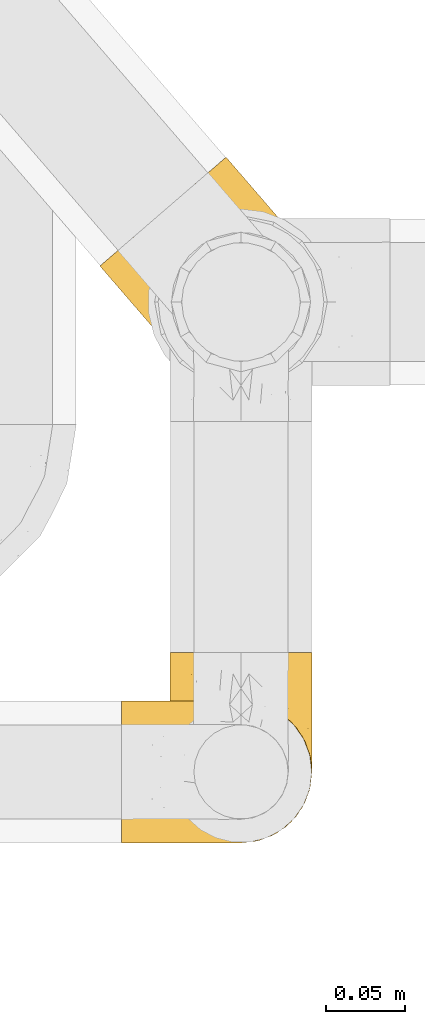
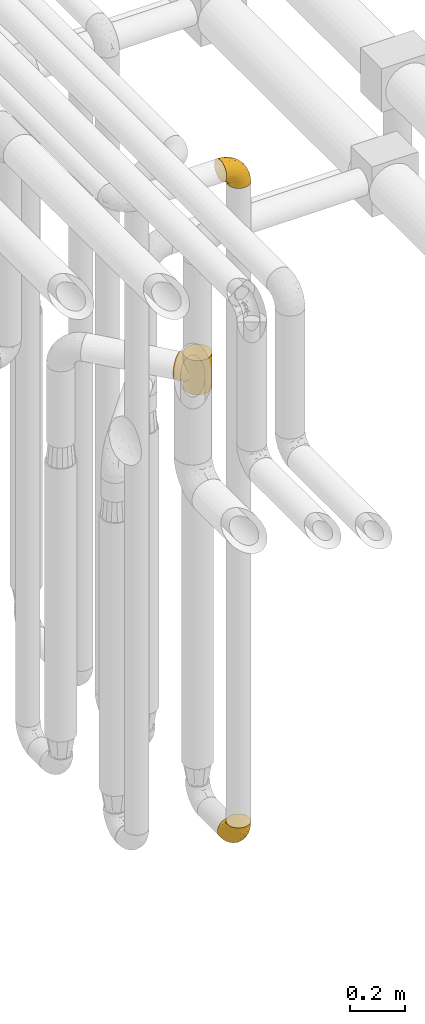
# One storey, part 195 of 827: 3 coverings.
"""IFC2X3 building model written with IfcOpenShell, lengths in millimetres."""

from ifc_helpers import new_model, entity, si_unit, converted_unit, derived_unit, direction, frame, origin, place, context, subcontext, project, spatial, faceted_brep, element, save


model = new_model("IFC2X3")

# Units and contexts
model_context = context("Model", 3, precision=0.01, world=origin(), true_north=direction((6.12303176911189e-17, 1.0)))
body_context = subcontext(model_context, "Body", "Model", "MODEL_VIEW")
ifc_project = project(units=[si_unit("LENGTHUNIT", "METRE", prefix="MILLI"), si_unit("AREAUNIT", "SQUARE_METRE"), si_unit("VOLUMEUNIT", "CUBIC_METRE"), converted_unit("PLANEANGLEUNIT", "DEGREE", entity("IfcRatioMeasure", 0.0174532925199433), si_unit("PLANEANGLEUNIT", "RADIAN"), dimensions=[0, 0, 0, 0, 0, 0, 0]), si_unit("MASSUNIT", "GRAM", prefix="KILO"), derived_unit("MASSDENSITYUNIT", [(si_unit("MASSUNIT", "GRAM", prefix="KILO"), 1), (si_unit("LENGTHUNIT", "METRE"), -3)]), derived_unit("MOMENTOFINERTIAUNIT", [(si_unit("LENGTHUNIT", "METRE"), 4)]), si_unit("TIMEUNIT", "SECOND"), si_unit("FREQUENCYUNIT", "HERTZ"), si_unit("THERMODYNAMICTEMPERATUREUNIT", "DEGREE_CELSIUS"), derived_unit("THERMALTRANSMITTANCEUNIT", [(si_unit("MASSUNIT", "GRAM", prefix="KILO"), 1), (si_unit("THERMODYNAMICTEMPERATUREUNIT", "KELVIN"), -1), (si_unit("TIMEUNIT", "SECOND"), -3)]), derived_unit("VOLUMETRICFLOWRATEUNIT", [(si_unit("LENGTHUNIT", "METRE"), 3), (si_unit("TIMEUNIT", "SECOND"), -1)]), derived_unit("MASSFLOWRATEUNIT", [(si_unit("MASSUNIT", "GRAM", prefix="KILO"), 1), (si_unit("TIMEUNIT", "SECOND"), -1)]), derived_unit("ROTATIONALFREQUENCYUNIT", [(si_unit("TIMEUNIT", "SECOND"), -1)]), si_unit("ELECTRICCURRENTUNIT", "AMPERE"), si_unit("ELECTRICVOLTAGEUNIT", "VOLT"), si_unit("POWERUNIT", "WATT"), si_unit("FORCEUNIT", "NEWTON", prefix="KILO"), si_unit("ILLUMINANCEUNIT", "LUX"), si_unit("LUMINOUSFLUXUNIT", "LUMEN"), si_unit("LUMINOUSINTENSITYUNIT", "CANDELA"), derived_unit("USERDEFINED", [(si_unit("MASSUNIT", "GRAM", prefix="KILO"), -1), (si_unit("LENGTHUNIT", "METRE"), -2), (si_unit("TIMEUNIT", "SECOND"), 3), (si_unit("LUMINOUSFLUXUNIT", "LUMEN"), 1)]), derived_unit("LINEARVELOCITYUNIT", [(si_unit("LENGTHUNIT", "METRE"), 1), (si_unit("TIMEUNIT", "SECOND"), -1)]), si_unit("PRESSUREUNIT", "PASCAL"), derived_unit("USERDEFINED", [(si_unit("LENGTHUNIT", "METRE"), -2), (si_unit("MASSUNIT", "GRAM", prefix="KILO"), 1), (si_unit("TIMEUNIT", "SECOND"), -2)]), derived_unit("LINEARFORCEUNIT", [(si_unit("MASSUNIT", "GRAM", prefix="KILO"), 1), (si_unit("LENGTHUNIT", "METRE"), 1), (si_unit("TIMEUNIT", "SECOND"), -2), (si_unit("LENGTHUNIT", "METRE"), -1)]), derived_unit("PLANARFORCEUNIT", [(si_unit("MASSUNIT", "GRAM", prefix="KILO"), 1), (si_unit("LENGTHUNIT", "METRE"), 1), (si_unit("TIMEUNIT", "SECOND"), -2), (si_unit("LENGTHUNIT", "METRE"), -2)])], contexts=[model_context])

# Site, building, storey
site_placement = place(None, origin())
site = spatial("IfcSite", under=ifc_project, at=site_placement, CompositionType="ELEMENT")
building_placement = place(site_placement, origin())
building = spatial("IfcBuilding", under=site, at=building_placement, CompositionType="ELEMENT")
storey_placement = place(building_placement, frame((0.0, 0.0, 28200.0)))
storey = spatial("IfcBuildingStorey", under=building, at=storey_placement, Name="08", CompositionType="ELEMENT", Elevation=28200.0)

# Coverings
covering_1_placement = place(storey_placement, frame((36928.29, 9734.28, 353.25)))
element("IfcCovering", 1, at=covering_1_placement, inside=storey, Name=":ADSK_", ObjectType=":ADSK_", PredefinedType="INSULATION", context=body_context, shape_type="Brep", body=[
    faceted_brep([(2.73, 36.69, 122.75), (6.07, 27.15, 122.75), (11.45, 18.59, 122.75), (18.6, 11.44, 122.75), (27.16, 6.06, 122.75), (36.7, 2.73, 122.75), (46.75, 1.6, 122.75), (56.8, 2.73, 122.75), (66.34, 6.07, 122.75), (74.9, 11.45, 122.75), (82.05, 18.6, 122.75), (87.43, 27.16, 122.75), (90.76, 36.7, 122.75), (91.9, 46.75, 122.75), (90.76, 56.8, 122.75), (87.42, 66.34, 122.75), (82.04, 74.9, 122.75), (74.89, 82.05, 122.75), (66.33, 87.43, 122.75), (56.79, 90.76, 122.75), (46.75, 91.9, 122.75), (36.69, 90.76, 122.75), (27.15, 87.42, 122.75), (18.59, 82.04, 122.75), (11.44, 74.89, 122.75), (6.06, 66.33, 122.75), (2.73, 56.79, 122.75), (1.6, 46.75, 122.75), (58.43, 122.75, 90.36), (69.32, 122.75, 85.85), (78.67, 122.75, 78.67), (85.85, 122.75, 69.32), (90.36, 122.75, 58.43), (91.9, 122.75, 46.75), (90.36, 122.75, 35.06), (85.85, 122.75, 24.17), (78.67, 122.75, 14.82), (69.32, 122.75, 7.64), (58.43, 122.75, 3.13), (46.75, 122.75, 1.6), (35.06, 122.75, 3.13), (24.17, 122.75, 7.64), (14.82, 122.75, 14.82), (7.64, 122.75, 24.17), (3.13, 122.75, 35.06), (1.6, 122.75, 46.75), (3.13, 122.75, 58.43), (7.64, 122.75, 69.32), (14.82, 122.75, 78.67), (24.17, 122.75, 85.85), (35.06, 122.75, 90.36), (46.75, 122.75, 91.9), (46.75, 24.73, 51.54), (38.29, 29.08, 47.17), (46.75, 38.13, 38.13), (46.75, 85.31, 7.52), (38.96, 93.59, 5.85), (46.75, 100.54, 5.11), (33.86, 63.54, 19.2), (31.42, 38.98, 38.98), (21.63, 50.71, 35.02), (30.84, 93.33, 8.21), (22.16, 75.2, 19.28), (20.56, 100.46, 12.19), (2.29, 41.6, 101.39), (7.18, 80.86, 34.43), (12.6, 94.87, 20.95), (14.0, 67.96, 30.74), (2.81, 52.16, 72.93), (6.65, 52.1, 56.64), (6.11, 36.74, 80.81), (16.62, 17.11, 93.43), (9.76, 23.24, 100.76), (12.46, 29.18, 74.27), (1.6, 52.53, 93.66), (1.6, 60.77, 81.33), (1.6, 69.01, 69.01), (2.46, 100.68, 40.87), (5.91, 103.79, 29.38), (36.97, 16.37, 67.05), (46.75, 7.52, 85.31), (33.09, 7.31, 93.68), (1.6, 93.66, 52.53), (1.6, 102.83, 50.71), (1.6, 112.01, 48.88), (25.62, 18.17, 72.77), (3.14, 71.97, 51.21), (23.92, 9.83, 101.18), (46.75, 5.11, 100.54), (13.58, 45.97, 48.74), (1.6, 48.88, 112.01), (1.6, 50.71, 102.83), (18.5, 22.83, 73.88), (46.75, 51.54, 24.73), (1.6, 81.33, 60.77), (4.96, 31.74, 103.08), (20.84, 32.48, 54.8), (46.75, 68.42, 16.13), (30.52, 25.33, 55.92), (46.75, 16.13, 68.42), (27.29, 92.29, 104.98), (36.89, 94.12, 108.58), (33.6, 100.97, 98.21), (2.54, 95.91, 61.56), (3.27, 107.9, 60.69), (16.85, 87.24, 100.0), (21.91, 95.46, 95.88), (13.5, 90.41, 90.81), (3.96, 74.17, 84.88), (3.52, 83.77, 73.29), (12.17, 76.72, 113.4), (18.93, 84.44, 109.8), (9.34, 76.42, 102.13), (3.12, 90.07, 67.29), (5.67, 99.69, 70.34), (2.51, 61.74, 95.15), (2.53, 58.16, 105.49), (8.35, 112.6, 71.5), (35.39, 110.45, 92.87), (46.75, 107.32, 96.03), (15.1, 108.48, 81.34), (5.27, 66.63, 107.44), (27.43, 115.23, 88.36), (24.89, 105.79, 90.43), (29.71, 89.6, 114.37), (5.07, 69.39, 98.41), (2.88, 66.99, 88.73), (9.69, 102.31, 76.89), (15.51, 99.54, 86.08), (2.27, 55.27, 112.64), (10.03, 82.03, 94.21), (46.75, 94.71, 112.22), (46.75, 96.03, 107.32), (8.83, 94.11, 79.95), (7.16, 84.21, 84.51), (46.75, 101.67, 101.67), (46.75, 112.22, 94.71), (78.39, 108.48, 81.34), (83.8, 102.31, 76.89), (77.97, 99.54, 86.08), (84.66, 94.11, 79.96), (58.1, 110.46, 92.87), (81.31, 76.74, 113.41), (91.9, 50.71, 102.83), (90.96, 58.17, 105.5), (91.22, 55.27, 112.64), (56.59, 94.12, 108.58), (66.18, 92.3, 104.98), (59.87, 100.98, 98.2), (88.42, 69.41, 98.4), (84.13, 76.44, 102.13), (88.22, 66.65, 107.44), (66.06, 115.24, 88.36), (91.9, 102.83, 50.71), (91.9, 112.01, 48.88), (83.44, 82.05, 94.22), (76.62, 87.25, 100.01), (85.14, 112.6, 71.5), (90.22, 107.9, 60.69), (91.9, 93.66, 52.53), (71.55, 95.48, 95.89), (63.77, 89.6, 114.37), (91.9, 60.77, 81.33), (91.9, 69.01, 69.01), (89.53, 74.17, 84.88), (91.9, 48.88, 112.01), (74.55, 84.45, 109.8), (90.95, 95.91, 61.56), (90.37, 90.07, 67.29), (91.9, 81.33, 60.77), (90.98, 61.75, 95.14), (89.97, 83.77, 73.29), (86.32, 84.21, 84.53), (91.9, 52.53, 93.66), (79.97, 90.42, 90.82), (90.61, 67.0, 88.73), (87.82, 99.69, 70.34), (68.6, 105.8, 90.43), (80.89, 94.87, 20.95), (86.31, 80.86, 34.43), (79.49, 67.95, 30.74), (71.33, 75.17, 19.29), (71.88, 50.65, 35.07), (90.35, 71.97, 51.21), (86.85, 52.08, 56.67), (72.67, 32.46, 54.85), (62.08, 38.98, 38.98), (87.58, 103.79, 29.38), (91.03, 100.68, 40.87), (59.62, 63.54, 19.2), (62.65, 93.32, 8.21), (54.53, 93.59, 5.85), (72.93, 100.44, 12.19), (90.68, 52.17, 72.93), (87.39, 36.75, 80.83), (91.2, 41.61, 101.39), (60.41, 7.31, 93.69), (76.88, 17.12, 93.43), (56.53, 16.37, 67.04), (83.74, 23.26, 100.76), (67.88, 18.17, 72.78), (62.99, 25.33, 55.93), (69.58, 9.84, 101.18), (81.04, 29.19, 74.27), (75.0, 22.84, 73.89), (88.53, 31.75, 103.09), (79.93, 45.96, 48.78), (55.21, 29.07, 47.19)], [[[0, 1, 2, 3, 4, 5, 6, 7, 8, 9, 10, 11, 12, 13, 14, 15, 16, 17, 18, 19, 20, 21, 22, 23, 24, 25, 26, 27]], [[28, 29, 30, 31, 32, 33, 34, 35, 36, 37, 38, 39, 40, 41, 42, 43, 44, 45, 46, 47, 48, 49, 50, 51]], [[52, 53, 54]], [[55, 56, 57]], [[58, 59, 60]], [[61, 62, 63]], [[27, 64, 0]], [[65, 66, 67]], [[41, 40, 61]], [[68, 69, 70]], [[66, 43, 42]], [[63, 42, 41]], [[71, 72, 73]], [[72, 2, 1]], [[68, 74, 75, 76]], [[45, 44, 77]], [[43, 78, 44]], [[79, 80, 81]], [[77, 82, 83, 84, 45]], [[79, 81, 85]], [[71, 2, 72]], [[65, 86, 77]], [[4, 81, 5]], [[66, 65, 78]], [[4, 3, 87]], [[81, 88, 5]], [[63, 66, 42]], [[68, 70, 64]], [[67, 60, 89]], [[71, 3, 2]], [[64, 27, 90, 91, 74]], [[92, 71, 73]], [[40, 57, 56]], [[59, 93, 54]], [[86, 76, 94, 82]], [[1, 0, 95]], [[58, 62, 61]], [[60, 96, 89]], [[85, 81, 87]], [[56, 97, 58]], [[65, 67, 69]], [[87, 81, 4]], [[67, 89, 69]], [[61, 63, 41]], [[95, 72, 1]], [[73, 72, 70]], [[69, 73, 70]], [[73, 89, 96]], [[3, 71, 87]], [[85, 87, 71]], [[58, 61, 56]], [[59, 58, 93]], [[76, 86, 68]], [[69, 89, 73]], [[68, 86, 69]], [[65, 69, 86]], [[68, 64, 74]], [[95, 64, 70]], [[98, 79, 85]], [[79, 52, 99, 80]], [[66, 62, 67]], [[62, 58, 60]], [[62, 60, 67]], [[59, 98, 96]], [[59, 96, 60]], [[96, 85, 92]], [[88, 81, 80]], [[88, 6, 5]], [[66, 63, 62]], [[64, 95, 0]], [[72, 95, 70]], [[77, 44, 78]], [[86, 82, 77]], [[40, 39, 57]], [[96, 98, 85]], [[40, 56, 61]], [[66, 78, 43]], [[77, 78, 65]], [[79, 98, 53]], [[96, 92, 73]], [[85, 71, 92]], [[97, 56, 55]], [[97, 93, 58]], [[53, 98, 59]], [[54, 53, 59]], [[79, 53, 52]], [[100, 101, 102]], [[46, 45, 84, 83]], [[103, 104, 82]], [[82, 104, 83]], [[105, 106, 107]], [[108, 109, 76]], [[110, 111, 112]], [[103, 113, 114]], [[115, 74, 116]], [[48, 47, 117]], [[118, 102, 119]], [[49, 48, 120]], [[74, 91, 116]], [[116, 121, 115]], [[49, 122, 50]], [[123, 106, 102]], [[124, 111, 22]], [[125, 126, 115]], [[23, 22, 111]], [[24, 110, 121]], [[120, 127, 128]], [[90, 26, 129]], [[27, 26, 90]], [[121, 125, 115]], [[24, 121, 25]], [[130, 105, 107]], [[129, 25, 116]], [[21, 20, 131]], [[120, 123, 122]], [[112, 105, 130]], [[50, 118, 51]], [[21, 124, 22]], [[101, 131, 132]], [[117, 120, 48]], [[24, 23, 110]], [[127, 114, 133]], [[75, 108, 76]], [[107, 134, 130]], [[133, 114, 113]], [[129, 116, 91]], [[25, 121, 116]], [[121, 112, 125]], [[75, 74, 115]], [[101, 135, 102]], [[131, 101, 21]], [[101, 100, 124]], [[128, 127, 133]], [[119, 136, 51, 118]], [[104, 47, 46]], [[83, 104, 46]], [[117, 104, 114]], [[101, 124, 21]], [[111, 124, 100]], [[102, 118, 123]], [[133, 134, 107]], [[111, 110, 23]], [[114, 104, 103]], [[94, 76, 109]], [[121, 110, 112]], [[122, 118, 50]], [[134, 109, 108]], [[133, 107, 128]], [[112, 108, 125]], [[126, 125, 108]], [[108, 75, 126]], [[75, 115, 126]], [[109, 134, 133]], [[130, 108, 112]], [[108, 130, 134]], [[105, 112, 111]], [[111, 100, 105]], [[106, 105, 100]], [[102, 106, 100]], [[128, 106, 123]], [[90, 129, 91]], [[25, 129, 26]], [[104, 117, 47]], [[117, 114, 127]], [[82, 94, 103]], [[113, 94, 109]], [[94, 113, 103]], [[133, 113, 109]], [[106, 128, 107]], [[123, 120, 128]], [[120, 122, 49]], [[118, 122, 123]], [[135, 101, 132]], [[135, 119, 102]], [[117, 127, 120]], [[30, 29, 137]], [[138, 139, 140]], [[51, 136, 119, 141]], [[142, 17, 16]], [[143, 144, 145]], [[146, 147, 148]], [[149, 150, 151]], [[152, 29, 28]], [[33, 32, 153, 154]], [[150, 155, 156]], [[157, 31, 30]], [[153, 158, 159]], [[29, 152, 137]], [[148, 141, 119]], [[156, 160, 147]], [[148, 135, 146]], [[137, 138, 157]], [[19, 161, 146]], [[162, 163, 164]], [[14, 13, 165]], [[153, 32, 158]], [[147, 161, 166]], [[18, 17, 166]], [[167, 168, 169]], [[166, 150, 156]], [[151, 150, 142]], [[151, 170, 149]], [[151, 16, 15]], [[171, 140, 172]], [[165, 143, 145]], [[173, 170, 144]], [[142, 166, 17]], [[19, 131, 20]], [[144, 170, 151]], [[18, 161, 19]], [[173, 144, 143]], [[140, 139, 174]], [[171, 164, 163]], [[164, 172, 155]], [[151, 15, 144]], [[145, 15, 14]], [[173, 162, 170]], [[149, 175, 164]], [[19, 146, 131]], [[132, 131, 146]], [[160, 148, 147]], [[159, 158, 167]], [[135, 132, 146]], [[158, 32, 31]], [[157, 158, 31]], [[167, 158, 176]], [[166, 161, 18]], [[146, 161, 147]], [[148, 177, 141]], [[171, 168, 140]], [[171, 163, 169]], [[151, 142, 16]], [[166, 142, 150]], [[152, 141, 177]], [[51, 141, 28]], [[138, 140, 176]], [[172, 140, 174]], [[175, 149, 170]], [[164, 150, 149]], [[170, 162, 175]], [[162, 164, 175]], [[155, 172, 174]], [[171, 172, 164]], [[155, 174, 156]], [[164, 155, 150]], [[160, 156, 174]], [[147, 166, 156]], [[139, 160, 174]], [[148, 160, 177]], [[15, 145, 144]], [[165, 145, 14]], [[137, 157, 30]], [[158, 157, 176]], [[168, 167, 176]], [[169, 159, 167]], [[140, 168, 176]], [[169, 168, 171]], [[137, 177, 139]], [[160, 139, 177]], [[141, 152, 28]], [[137, 152, 177]], [[148, 119, 135]], [[157, 138, 176]], [[139, 138, 137]], [[178, 179, 180]], [[181, 180, 182]], [[179, 183, 184]], [[185, 186, 182]], [[187, 188, 179]], [[188, 33, 154, 153, 159]], [[181, 189, 190]], [[35, 34, 187]], [[191, 38, 190]], [[192, 178, 181]], [[179, 184, 180]], [[192, 190, 37]], [[37, 190, 38]], [[36, 35, 178]], [[54, 93, 186]], [[35, 187, 178]], [[193, 194, 184]], [[195, 173, 143, 165, 13]], [[195, 193, 173]], [[193, 163, 162, 173]], [[13, 12, 195]], [[8, 7, 196]], [[9, 197, 10]], [[198, 80, 99, 52]], [[196, 7, 88]], [[197, 199, 10]], [[182, 189, 181]], [[200, 198, 201]], [[200, 196, 198]], [[9, 8, 202]], [[194, 199, 203]], [[192, 37, 36]], [[80, 196, 88]], [[183, 159, 169, 163]], [[188, 34, 33]], [[202, 200, 197]], [[185, 203, 204]], [[202, 8, 196]], [[10, 199, 11]], [[12, 11, 205]], [[38, 191, 57]], [[189, 97, 191]], [[203, 199, 197]], [[205, 199, 194]], [[204, 203, 197]], [[184, 203, 206]], [[200, 202, 196]], [[197, 9, 202]], [[207, 54, 186]], [[97, 55, 191]], [[194, 203, 184]], [[183, 163, 193]], [[184, 206, 180]], [[183, 193, 184]], [[205, 195, 12]], [[193, 195, 194]], [[80, 198, 196]], [[207, 186, 201]], [[182, 180, 206]], [[181, 178, 180]], [[185, 182, 206]], [[182, 186, 189]], [[203, 185, 206]], [[185, 200, 201]], [[7, 6, 88]], [[178, 192, 36]], [[190, 192, 181]], [[199, 205, 11]], [[195, 205, 194]], [[159, 183, 188]], [[179, 188, 183]], [[57, 191, 55]], [[57, 39, 38]], [[189, 191, 190]], [[188, 187, 34]], [[178, 187, 179]], [[186, 93, 189]], [[197, 200, 204]], [[185, 204, 200]], [[189, 93, 97]], [[207, 198, 52]], [[185, 201, 186]], [[198, 207, 201]], [[54, 207, 52]]]),
])
covering_2_placement = place(storey_placement, frame((36897.44, 9734.28, 3322.4)))
element("IfcCovering", 2, at=covering_2_placement, inside=storey, Name=":ADSK_", ObjectType=":ADSK_", PredefinedType="INSULATION", context=body_context, shape_type="Brep", body=[
    faceted_brep([(1.6, 2.73, 87.65), (1.6, 6.07, 97.19), (1.6, 11.45, 105.75), (1.6, 18.6, 112.9), (1.6, 27.16, 118.28), (1.6, 36.7, 121.61), (1.6, 46.75, 122.75), (1.6, 56.8, 121.61), (1.6, 66.34, 118.27), (1.6, 74.9, 112.89), (1.6, 82.05, 105.74), (1.6, 87.43, 97.18), (1.6, 90.76, 87.64), (1.6, 91.9, 77.6), (1.6, 90.76, 67.54), (1.6, 87.42, 58.0), (1.6, 82.04, 49.44), (1.6, 74.89, 42.29), (1.6, 66.33, 36.91), (1.6, 56.79, 33.58), (1.6, 46.75, 32.45), (1.6, 36.69, 33.58), (1.6, 27.15, 36.92), (1.6, 18.59, 42.3), (1.6, 11.44, 49.45), (1.6, 6.06, 58.01), (1.6, 2.73, 67.55), (1.6, 1.6, 77.6), (33.98, 58.43, 1.6), (38.49, 69.32, 1.6), (45.67, 78.67, 1.6), (55.02, 85.85, 1.6), (65.91, 90.36, 1.6), (77.6, 91.9, 1.6), (89.28, 90.36, 1.6), (100.17, 85.85, 1.6), (109.52, 78.67, 1.6), (116.7, 69.32, 1.6), (121.21, 58.43, 1.6), (122.75, 46.75, 1.6), (121.21, 35.06, 1.6), (116.7, 24.17, 1.6), (109.52, 14.82, 1.6), (100.17, 7.64, 1.6), (89.28, 3.13, 1.6), (77.6, 1.6, 1.6), (65.91, 3.13, 1.6), (55.02, 7.64, 1.6), (45.67, 14.82, 1.6), (38.49, 24.17, 1.6), (33.98, 35.06, 1.6), (32.45, 46.75, 1.6), (72.81, 46.75, 99.61), (77.17, 38.29, 95.26), (86.21, 46.75, 86.21), (116.82, 46.75, 39.03), (118.49, 38.96, 30.75), (119.23, 46.75, 23.8), (105.14, 33.86, 60.8), (85.37, 31.42, 85.37), (89.33, 21.63, 73.64), (116.14, 30.84, 31.01), (105.06, 22.16, 49.14), (112.15, 20.56, 23.88), (22.95, 2.29, 82.74), (89.91, 7.18, 43.48), (103.39, 12.6, 29.47), (93.6, 14.0, 56.38), (51.41, 2.81, 72.18), (67.71, 6.65, 72.24), (43.53, 6.11, 87.6), (30.91, 16.62, 107.24), (23.58, 9.76, 101.1), (50.07, 12.46, 95.16), (30.68, 1.6, 71.81), (43.01, 1.6, 63.57), (55.34, 1.6, 55.34), (83.48, 2.46, 23.66), (94.96, 5.91, 20.55), (57.29, 36.97, 107.97), (39.03, 46.75, 116.82), (30.66, 33.09, 117.03), (71.81, 1.6, 30.68), (73.63, 1.6, 21.51), (75.46, 1.6, 12.33), (51.57, 25.62, 106.17), (73.13, 3.14, 52.37), (23.16, 23.92, 114.51), (23.8, 46.75, 119.23), (75.6, 13.58, 78.37), (12.33, 1.6, 75.46), (21.51, 1.6, 73.63), (50.46, 18.5, 101.51), (99.61, 46.75, 72.81), (63.57, 1.6, 43.01), (21.26, 4.96, 92.6), (69.54, 20.84, 91.86), (108.21, 46.75, 55.92), (68.42, 30.52, 99.01), (55.92, 46.75, 108.21), (19.36, 27.29, 32.05), (15.76, 36.89, 30.22), (26.13, 33.6, 23.37), (62.78, 2.54, 28.43), (63.65, 3.27, 16.44), (24.34, 16.85, 37.1), (28.46, 21.91, 28.88), (33.53, 13.5, 33.93), (39.46, 3.96, 50.17), (51.05, 3.52, 40.57), (10.94, 12.17, 47.62), (14.55, 18.93, 39.9), (22.21, 9.34, 47.92), (57.05, 3.12, 34.27), (54.0, 5.67, 24.65), (29.19, 2.51, 62.6), (18.85, 2.53, 66.18), (52.84, 8.35, 11.74), (31.47, 35.39, 13.89), (28.31, 46.75, 17.02), (43.0, 15.1, 15.86), (16.9, 5.27, 57.71), (35.98, 27.43, 9.11), (33.91, 24.89, 18.55), (9.97, 29.71, 34.74), (25.93, 5.07, 54.95), (35.61, 2.88, 57.35), (47.45, 9.69, 22.03), (38.26, 15.51, 24.8), (11.7, 2.27, 69.07), (30.13, 10.03, 42.31), (12.12, 46.75, 29.63), (17.02, 46.75, 28.31), (44.39, 8.83, 30.23), (39.83, 7.16, 40.13), (22.67, 46.75, 22.67), (29.63, 46.75, 12.12), (43.0, 78.39, 15.86), (47.45, 83.8, 22.03), (38.26, 77.97, 24.8), (44.38, 84.66, 30.23), (31.47, 58.1, 13.88), (10.93, 81.31, 47.61), (21.51, 91.9, 73.63), (18.84, 90.96, 66.17), (11.7, 91.22, 69.07), (15.76, 56.59, 30.22), (19.36, 66.18, 32.04), (26.14, 59.87, 23.36), (25.94, 88.42, 54.93), (22.21, 84.13, 47.91), (16.9, 88.22, 57.69), (35.98, 66.06, 9.1), (73.63, 91.9, 21.51), (75.46, 91.9, 12.33), (30.12, 83.44, 42.29), (24.33, 76.62, 37.09), (52.84, 85.14, 11.74), (63.65, 90.22, 16.44), (71.81, 91.9, 30.68), (28.45, 71.55, 28.86), (9.97, 63.77, 34.74), (43.01, 91.9, 63.57), (55.34, 91.9, 55.34), (39.46, 89.53, 50.17), (12.33, 91.9, 75.46), (14.54, 74.55, 39.89), (62.78, 90.95, 28.43), (57.05, 90.37, 34.27), (63.57, 91.9, 43.01), (29.2, 90.98, 62.59), (51.05, 89.97, 40.57), (39.81, 86.32, 40.13), (30.68, 91.9, 71.81), (33.52, 79.97, 33.92), (35.61, 90.61, 57.34), (54.0, 87.82, 24.65), (33.91, 68.6, 18.54), (103.39, 80.89, 29.47), (89.91, 86.31, 43.48), (93.6, 79.49, 56.4), (105.05, 71.33, 49.17), (89.27, 71.88, 73.69), (73.13, 90.35, 52.37), (67.67, 86.85, 72.26), (69.49, 72.67, 91.88), (85.36, 62.08, 85.36), (94.96, 87.58, 20.55), (83.48, 91.03, 23.66), (105.14, 59.62, 60.8), (116.13, 62.65, 31.02), (118.49, 54.53, 30.75), (112.15, 72.93, 23.9), (51.41, 90.68, 72.17), (43.51, 87.39, 87.59), (22.95, 91.2, 82.74), (30.66, 60.41, 117.03), (30.91, 76.88, 107.23), (57.3, 56.53, 107.97), (23.58, 83.74, 101.08), (51.56, 67.88, 106.17), (68.41, 62.99, 99.01), (23.16, 69.58, 114.5), (50.07, 81.04, 95.15), (50.45, 75.0, 101.5), (21.25, 88.53, 92.59), (75.56, 79.93, 78.38), (77.16, 55.21, 95.27)], [[[0, 1, 2, 3, 4, 5, 6, 7, 8, 9, 10, 11, 12, 13, 14, 15, 16, 17, 18, 19, 20, 21, 22, 23, 24, 25, 26, 27]], [[28, 29, 30, 31, 32, 33, 34, 35, 36, 37, 38, 39, 40, 41, 42, 43, 44, 45, 46, 47, 48, 49, 50, 51]], [[52, 53, 54]], [[55, 56, 57]], [[58, 59, 60]], [[61, 62, 63]], [[27, 64, 0]], [[65, 66, 67]], [[41, 40, 61]], [[68, 69, 70]], [[66, 43, 42]], [[63, 42, 41]], [[71, 72, 73]], [[72, 2, 1]], [[68, 74, 75, 76]], [[45, 44, 77]], [[43, 78, 44]], [[79, 80, 81]], [[77, 82, 83, 84, 45]], [[79, 81, 85]], [[71, 2, 72]], [[65, 86, 77]], [[4, 81, 5]], [[66, 65, 78]], [[4, 3, 87]], [[81, 88, 5]], [[63, 66, 42]], [[68, 70, 64]], [[67, 60, 89]], [[71, 3, 2]], [[64, 27, 90, 91, 74]], [[92, 71, 73]], [[40, 57, 56]], [[59, 93, 54]], [[86, 76, 94, 82]], [[1, 0, 95]], [[58, 62, 61]], [[60, 96, 89]], [[85, 81, 87]], [[56, 97, 58]], [[65, 67, 69]], [[87, 81, 4]], [[67, 89, 69]], [[61, 63, 41]], [[95, 72, 1]], [[73, 72, 70]], [[69, 73, 70]], [[73, 89, 96]], [[3, 71, 87]], [[85, 87, 71]], [[58, 61, 56]], [[59, 58, 93]], [[76, 86, 68]], [[69, 89, 73]], [[68, 86, 69]], [[65, 69, 86]], [[68, 64, 74]], [[95, 64, 70]], [[98, 79, 85]], [[79, 52, 99, 80]], [[66, 62, 67]], [[62, 58, 60]], [[62, 60, 67]], [[59, 98, 96]], [[59, 96, 60]], [[96, 85, 92]], [[88, 81, 80]], [[88, 6, 5]], [[66, 63, 62]], [[64, 95, 0]], [[72, 95, 70]], [[77, 44, 78]], [[86, 82, 77]], [[40, 39, 57]], [[96, 98, 85]], [[40, 56, 61]], [[66, 78, 43]], [[77, 78, 65]], [[79, 98, 53]], [[96, 92, 73]], [[85, 71, 92]], [[97, 56, 55]], [[97, 93, 58]], [[53, 98, 59]], [[54, 53, 59]], [[79, 53, 52]], [[100, 101, 102]], [[46, 45, 84, 83]], [[103, 104, 82]], [[82, 104, 83]], [[105, 106, 107]], [[108, 109, 76]], [[110, 111, 112]], [[103, 113, 114]], [[115, 74, 116]], [[48, 47, 117]], [[118, 102, 119]], [[49, 48, 120]], [[74, 91, 116]], [[116, 121, 115]], [[49, 122, 50]], [[123, 106, 102]], [[124, 111, 22]], [[125, 126, 115]], [[23, 22, 111]], [[24, 110, 121]], [[120, 127, 128]], [[90, 26, 129]], [[27, 26, 90]], [[121, 125, 115]], [[24, 121, 25]], [[130, 105, 107]], [[129, 25, 116]], [[21, 20, 131]], [[120, 123, 122]], [[112, 105, 130]], [[50, 118, 51]], [[21, 124, 22]], [[101, 131, 132]], [[117, 120, 48]], [[24, 23, 110]], [[127, 114, 133]], [[75, 108, 76]], [[107, 134, 130]], [[133, 114, 113]], [[129, 116, 91]], [[25, 121, 116]], [[121, 112, 125]], [[75, 74, 115]], [[101, 135, 102]], [[131, 101, 21]], [[101, 100, 124]], [[128, 127, 133]], [[119, 136, 51, 118]], [[104, 47, 46]], [[83, 104, 46]], [[117, 104, 114]], [[101, 124, 21]], [[111, 124, 100]], [[102, 118, 123]], [[133, 134, 107]], [[111, 110, 23]], [[114, 104, 103]], [[94, 76, 109]], [[121, 110, 112]], [[122, 118, 50]], [[134, 109, 108]], [[133, 107, 128]], [[112, 108, 125]], [[126, 125, 108]], [[108, 75, 126]], [[75, 115, 126]], [[109, 134, 133]], [[130, 108, 112]], [[108, 130, 134]], [[105, 112, 111]], [[111, 100, 105]], [[106, 105, 100]], [[102, 106, 100]], [[128, 106, 123]], [[90, 129, 91]], [[25, 129, 26]], [[104, 117, 47]], [[117, 114, 127]], [[82, 94, 103]], [[113, 94, 109]], [[94, 113, 103]], [[133, 113, 109]], [[106, 128, 107]], [[123, 120, 128]], [[120, 122, 49]], [[118, 122, 123]], [[135, 101, 132]], [[135, 119, 102]], [[117, 127, 120]], [[30, 29, 137]], [[138, 139, 140]], [[51, 136, 119, 141]], [[142, 17, 16]], [[143, 144, 145]], [[146, 147, 148]], [[149, 150, 151]], [[152, 29, 28]], [[33, 32, 153, 154]], [[150, 155, 156]], [[157, 31, 30]], [[153, 158, 159]], [[29, 152, 137]], [[148, 141, 119]], [[156, 160, 147]], [[148, 135, 146]], [[137, 138, 157]], [[19, 161, 146]], [[162, 163, 164]], [[14, 13, 165]], [[153, 32, 158]], [[147, 161, 166]], [[18, 17, 166]], [[167, 168, 169]], [[166, 150, 156]], [[151, 150, 142]], [[151, 170, 149]], [[151, 16, 15]], [[171, 140, 172]], [[165, 143, 145]], [[173, 170, 144]], [[142, 166, 17]], [[19, 131, 20]], [[144, 170, 151]], [[18, 161, 19]], [[173, 144, 143]], [[140, 139, 174]], [[171, 164, 163]], [[164, 172, 155]], [[151, 15, 144]], [[145, 15, 14]], [[173, 162, 170]], [[149, 175, 164]], [[19, 146, 131]], [[132, 131, 146]], [[160, 148, 147]], [[159, 158, 167]], [[135, 132, 146]], [[158, 32, 31]], [[157, 158, 31]], [[167, 158, 176]], [[166, 161, 18]], [[146, 161, 147]], [[148, 177, 141]], [[171, 168, 140]], [[171, 163, 169]], [[151, 142, 16]], [[166, 142, 150]], [[152, 141, 177]], [[51, 141, 28]], [[138, 140, 176]], [[172, 140, 174]], [[175, 149, 170]], [[164, 150, 149]], [[170, 162, 175]], [[162, 164, 175]], [[155, 172, 174]], [[171, 172, 164]], [[155, 174, 156]], [[164, 155, 150]], [[160, 156, 174]], [[147, 166, 156]], [[139, 160, 174]], [[148, 160, 177]], [[15, 145, 144]], [[165, 145, 14]], [[137, 157, 30]], [[158, 157, 176]], [[168, 167, 176]], [[169, 159, 167]], [[140, 168, 176]], [[169, 168, 171]], [[137, 177, 139]], [[160, 139, 177]], [[141, 152, 28]], [[137, 152, 177]], [[148, 119, 135]], [[157, 138, 176]], [[139, 138, 137]], [[178, 179, 180]], [[181, 180, 182]], [[179, 183, 184]], [[185, 186, 182]], [[187, 188, 179]], [[188, 33, 154, 153, 159]], [[181, 189, 190]], [[35, 34, 187]], [[191, 38, 190]], [[192, 178, 181]], [[179, 184, 180]], [[192, 190, 37]], [[37, 190, 38]], [[36, 35, 178]], [[54, 93, 186]], [[35, 187, 178]], [[193, 194, 184]], [[195, 173, 143, 165, 13]], [[195, 193, 173]], [[193, 163, 162, 173]], [[13, 12, 195]], [[8, 7, 196]], [[9, 197, 10]], [[198, 80, 99, 52]], [[196, 7, 88]], [[197, 199, 10]], [[182, 189, 181]], [[200, 198, 201]], [[200, 196, 198]], [[9, 8, 202]], [[194, 199, 203]], [[192, 37, 36]], [[80, 196, 88]], [[183, 159, 169, 163]], [[188, 34, 33]], [[202, 200, 197]], [[185, 203, 204]], [[202, 8, 196]], [[10, 199, 11]], [[12, 11, 205]], [[38, 191, 57]], [[189, 97, 191]], [[203, 199, 197]], [[205, 199, 194]], [[204, 203, 197]], [[184, 203, 206]], [[200, 202, 196]], [[197, 9, 202]], [[207, 54, 186]], [[97, 55, 191]], [[194, 203, 184]], [[183, 163, 193]], [[184, 206, 180]], [[183, 193, 184]], [[205, 195, 12]], [[193, 195, 194]], [[80, 198, 196]], [[207, 186, 201]], [[182, 180, 206]], [[181, 178, 180]], [[185, 182, 206]], [[182, 186, 189]], [[203, 185, 206]], [[185, 200, 201]], [[7, 6, 88]], [[178, 192, 36]], [[190, 192, 181]], [[199, 205, 11]], [[195, 205, 194]], [[159, 183, 188]], [[179, 188, 183]], [[57, 191, 55]], [[57, 39, 38]], [[189, 191, 190]], [[188, 187, 34]], [[178, 187, 179]], [[186, 93, 189]], [[197, 200, 204]], [[185, 204, 200]], [[189, 93, 97]], [[207, 198, 52]], [[185, 201, 186]], [[198, 207, 201]], [[54, 207, 52]]]),
])
covering_3_placement = place(storey_placement, frame((36883.62, 10025.7, 2229.0)))
element("IfcCovering", 3, at=covering_3_placement, inside=storey, Name=":ADSK_", ObjectType=":ADSK_", PredefinedType="INSULATION", context=body_context, shape_type="Brep", body=[
    faceted_brep([(126.54, 94.25, 68.86), (131.57, 89.16, 0.0), (121.24, 98.37, 0.0), (108.86, 104.6, 0.0), (114.42, 102.3, 54.84), (99.72, 106.9, 41.76), (95.3, 107.41, 0.0), (107.37, 105.09, 48.13), (131.57, 89.16, 76.0), (126.54, 94.25, 83.14), (131.57, 89.16, 152.0), (120.81, 98.66, 61.78), (91.49, 107.55, 35.89), (81.48, 106.61, 0.0), (73.82, 104.55, 26.62), (74.9, 104.44, 0.0), (68.33, 102.27, 0.0), (62.54, 98.47, 0.0), (56.75, 94.67, 0.0), (56.75, 94.67, 22.95), (62.54, 98.47, 152.0), (56.75, 94.67, 129.05), (56.75, 94.67, 152.0), (82.79, 106.85, 30.74), (64.96, 100.49, 23.9), (49.11, 86.52, 24.13), (49.11, 86.52, 127.87), (47.54, 84.33, 0.0), (43.53, 77.34, 27.43), (44.43, 78.14, 0.0), (41.31, 71.96, 0.0), (38.5, 58.4, 0.0), (38.51, 58.49, 38.42), (40.06, 67.84, 32.36), (38.59, 49.55, 45.24), (39.3, 44.57, 0.0), (40.07, 41.15, 52.57), (43.64, 31.42, 0.0), (46.51, 26.24, 68.06), (51.25, 19.84, 0.0), (42.75, 33.36, 60.22), (51.25, 19.84, 76.0), (46.51, 26.24, 83.94), (51.25, 19.84, 152.0), (114.49, 6.74, 152.0), (126.07, 14.34, 152.0), (135.28, 24.68, 152.0), (141.51, 37.05, 152.0), (144.32, 50.61, 152.0), (143.52, 64.43, 152.0), (139.18, 77.58, 152.0), (121.24, 98.37, 152.0), (108.86, 104.6, 152.0), (95.3, 107.41, 152.0), (81.48, 106.61, 152.0), (74.9, 104.44, 152.0), (68.33, 102.27, 152.0), (47.54, 84.33, 152.0), (44.43, 78.14, 152.0), (41.31, 71.96, 152.0), (38.5, 58.4, 152.0), (39.3, 44.57, 152.0), (43.64, 31.42, 152.0), (61.58, 10.63, 152.0), (73.96, 4.41, 152.0), (87.52, 1.6, 152.0), (101.34, 2.39, 152.0), (139.18, 77.58, 0.0), (143.52, 64.43, 0.0), (144.32, 50.61, 0.0), (141.51, 37.05, 0.0), (135.28, 24.68, 0.0), (126.07, 14.34, 0.0), (114.49, 6.74, 0.0), (101.34, 2.39, 0.0), (87.52, 1.6, 0.0), (73.96, 4.41, 0.0), (61.58, 10.63, 0.0), (120.81, 98.66, 90.22), (114.42, 102.3, 97.16), (107.37, 105.09, 103.87), (99.72, 106.9, 110.24), (91.49, 107.55, 116.11), (82.79, 106.85, 121.26), (73.82, 104.55, 125.38), (64.96, 100.49, 128.1), (43.53, 77.34, 124.57), (40.06, 67.84, 119.64), (38.51, 58.49, 113.58), (40.07, 41.15, 99.43), (42.75, 33.36, 91.78), (38.59, 49.55, 106.76), (81.92, 146.7, 76.0), (80.55, 145.52, 62.27), (76.54, 142.06, 49.47), (70.16, 136.55, 38.49), (61.84, 129.37, 30.06), (57.0, 125.19, 27.41), (52.15, 121.01, 24.76), (46.96, 116.53, 23.85), (41.76, 112.04, 22.95), (31.36, 103.07, 24.76), (26.52, 98.89, 27.41), (21.68, 94.71, 30.06), (13.36, 87.54, 38.49), (6.98, 82.03, 49.47), (2.96, 78.56, 62.27), (1.6, 77.38, 76.0), (2.96, 78.56, 89.73), (6.98, 82.03, 102.53), (13.36, 87.54, 113.51), (21.68, 94.71, 121.94), (26.52, 98.89, 124.59), (31.36, 103.07, 127.24), (41.76, 112.04, 129.05), (46.96, 116.53, 128.15), (52.15, 121.01, 127.24), (57.0, 125.19, 124.59), (61.84, 129.37, 121.94), (70.16, 136.55, 113.51), (76.54, 142.06, 102.53), (80.55, 145.52, 89.73)], [[[0, 1, 2]], [[2, 3, 4]], [[5, 3, 6]], [[5, 7, 3]], [[0, 8, 1]], [[8, 9, 10]], [[4, 11, 2]], [[7, 4, 3]], [[0, 2, 11]], [[12, 6, 13]], [[14, 13, 15, 16]], [[17, 18, 19]], [[20, 21, 22]], [[23, 12, 13]], [[24, 14, 16]], [[24, 17, 19]], [[24, 16, 17]], [[23, 13, 14]], [[6, 12, 5]], [[25, 19, 18]], [[21, 26, 22]], [[25, 18, 27]], [[28, 27, 29, 30]], [[28, 25, 27]], [[31, 32, 33]], [[28, 30, 33]], [[33, 30, 31]], [[34, 31, 35]], [[36, 35, 37]], [[38, 37, 39]], [[36, 34, 35]], [[38, 40, 37]], [[41, 38, 39]], [[42, 41, 43]], [[36, 37, 40]], [[31, 34, 32]], [[44, 45, 46, 47, 48, 49, 50, 10, 51, 52, 53, 54, 55, 56, 20, 22, 57, 58, 59, 60, 61, 62, 43, 63, 64, 65, 66]], [[1, 67, 68, 69, 70, 71, 72, 73, 74, 75, 76, 77, 39, 37, 35, 31, 30, 29, 27, 18, 17, 16, 15, 13, 6, 3, 2]], [[70, 69, 48, 47]], [[45, 72, 71, 46]], [[46, 71, 70, 47]], [[49, 68, 67, 50]], [[1, 8, 10, 50, 67]], [[48, 69, 68, 49]], [[78, 79, 51]], [[9, 78, 51]], [[10, 9, 51]], [[52, 80, 81]], [[52, 51, 79]], [[52, 81, 53]], [[80, 52, 79]], [[82, 83, 54]], [[84, 56, 55, 54]], [[84, 85, 56]], [[21, 20, 85]], [[83, 84, 54]], [[53, 82, 54]], [[85, 20, 56]], [[82, 53, 81]], [[26, 86, 57]], [[59, 87, 60]], [[86, 59, 58, 57]], [[86, 87, 59]], [[22, 26, 57]], [[87, 88, 60]], [[89, 90, 62]], [[90, 42, 62]], [[60, 91, 61]], [[91, 60, 88]], [[89, 61, 91]], [[89, 62, 61]], [[42, 43, 62]], [[41, 39, 77, 63, 43]], [[63, 77, 76, 64]], [[76, 75, 65, 64]], [[65, 75, 74, 66]], [[66, 74, 73, 44]], [[44, 73, 72, 45]], [[92, 93, 94, 95, 96, 97, 98, 99, 100, 101, 102, 103, 104, 105, 106, 107, 108, 109, 110, 111, 112, 113, 114, 115, 116, 117, 118, 119, 120, 121]], [[24, 99, 98]], [[96, 95, 12]], [[14, 98, 97, 96]], [[19, 99, 24]], [[19, 100, 99]], [[23, 14, 96]], [[12, 23, 96]], [[24, 98, 14]], [[95, 5, 12]], [[7, 5, 94]], [[94, 5, 95]], [[4, 94, 93]], [[0, 93, 92]], [[4, 7, 94]], [[0, 11, 93]], [[8, 0, 92]], [[4, 93, 11]], [[9, 92, 121]], [[121, 120, 79]], [[81, 120, 119]], [[81, 80, 120]], [[9, 8, 92]], [[79, 78, 121]], [[80, 79, 120]], [[9, 121, 78]], [[82, 119, 118]], [[84, 118, 117, 116]], [[115, 114, 21]], [[83, 82, 118]], [[85, 84, 116]], [[85, 115, 21]], [[85, 116, 115]], [[83, 118, 84]], [[119, 82, 81]], [[26, 21, 114]], [[26, 114, 113]], [[86, 113, 112, 111]], [[86, 26, 113]], [[110, 88, 87]], [[86, 111, 87]], [[87, 111, 110]], [[91, 110, 109]], [[89, 109, 108]], [[42, 108, 107]], [[89, 91, 109]], [[42, 90, 108]], [[41, 42, 107]], [[89, 108, 90]], [[110, 91, 88]], [[38, 107, 106]], [[106, 105, 36]], [[34, 105, 104]], [[34, 36, 105]], [[38, 41, 107]], [[36, 40, 106]], [[38, 106, 40]], [[33, 104, 103]], [[28, 103, 102, 101]], [[25, 101, 100]], [[33, 32, 104]], [[25, 28, 101]], [[19, 25, 100]], [[33, 103, 28]], [[104, 32, 34]]]),
])

save(model, "model.ifc")
